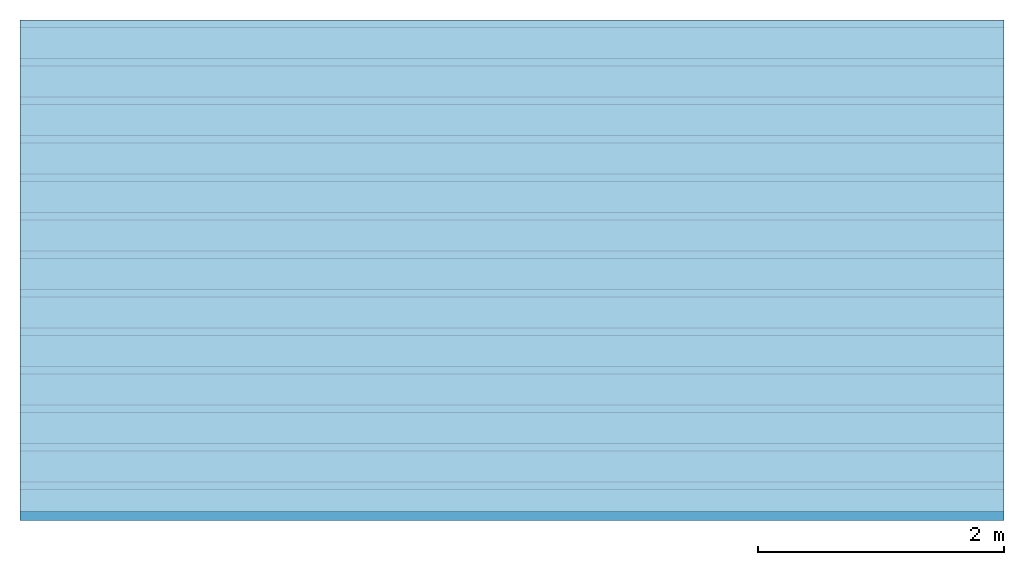
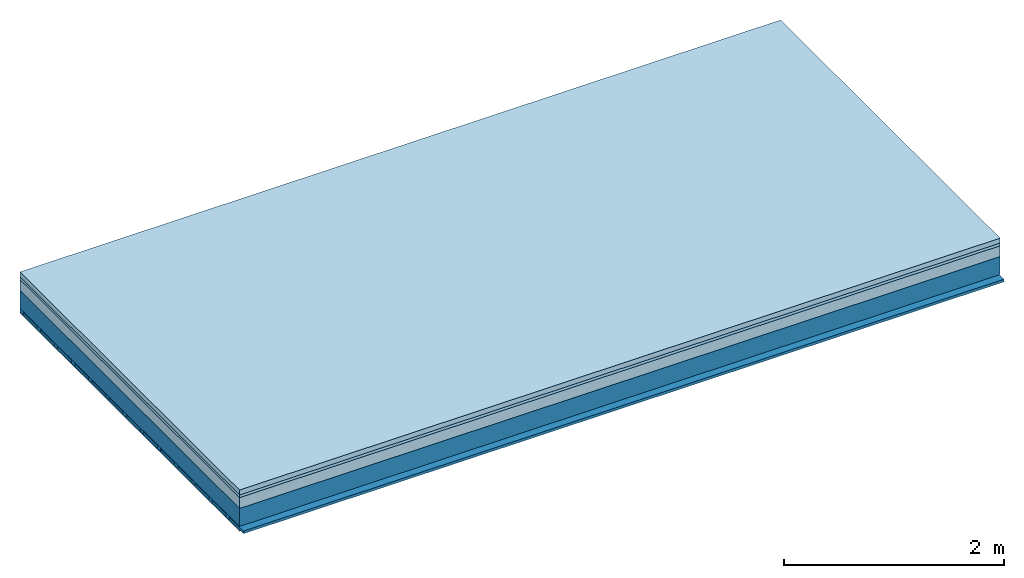
# One storey: 4 plates, 3 members, 1 element without a shape of its own.
"""IFC4 building model written with IfcOpenShell, lengths in metres."""

from ifc_helpers import new_model, si_unit, derived_unit, direction, frame, frame_2d, origin, origin_with_axes, place, context, project, spatial, rectangle, extrude, material, layer, layer_set, type_object, element, aggregate, save


model = new_model("IFC4")

# Units and contexts
plan_context = context("Plan", 3, precision=1e-05, world=origin(), true_north=direction((0.0, 1.0)))
model_context = context("Model", 3, precision=1e-05, world=origin(), true_north=direction((0.0, 1.0)))
ifc_project = project(units=[si_unit("LENGTHUNIT", "METRE"), derived_unit("SOUNDPRESSUREUNIT", [(si_unit("PRESSUREUNIT", "PASCAL", prefix="MICRO"), 0)]), si_unit("ENERGYUNIT", "JOULE", prefix="MEGA"), si_unit("MASSUNIT", "GRAM", prefix="KILO"), derived_unit("THERMALTRANSMITTANCEUNIT", [(si_unit("POWERUNIT", "WATT"), 1), (si_unit("AREAUNIT", "SQUARE_METRE"), -1), (si_unit("THERMODYNAMICTEMPERATUREUNIT", "KELVIN"), -1)]), derived_unit("AREADENSITYUNIT", [(si_unit("MASSUNIT", "GRAM", prefix="KILO"), 1), (si_unit("AREAUNIT", "SQUARE_METRE"), -1)]), derived_unit("USERDEFINED", [(si_unit("ENERGYUNIT", "JOULE", prefix="MEGA"), 1), (si_unit("AREAUNIT", "SQUARE_METRE"), -1)])], contexts=[plan_context, model_context])

# Site, building, storey
site = spatial("IfcSite", under=ifc_project)
building_placement = place(None, origin())
building = spatial("IfcBuilding", under=site, at=building_placement)
storey_placement = place(building_placement, origin())
storey = spatial("IfcBuildingStorey", under=building, at=storey_placement)

# Slab, members, plates
ifc_material_1 = material(Category="04.005")
ifc_layer_1 = layer(ifc_material_1, 0.055, Name="On-material")
ifc_material_2 = material()
ifc_layer_2 = layer(ifc_material_2, 0.03, Name="Impact sound insulation")
ifc_material_3 = material(Category="03.011")
ifc_layer_3 = layer(ifc_material_3, 0.12, Name="on Supporting structure")
ifc_layer_4 = layer(None, 0.2, Name="Supporting structure")
ifc_material_4 = material(Name="of the art")
ifc_layer_5 = layer(ifc_material_4, 0.0, Name="Bond")
ifc_layer_6 = layer(None, 0.04, Name="Battens / profiles")
ifc_material_5 = material(Category="03.007")
ifc_layer_7 = layer(ifc_material_5, 0.015, Name="Ceiling covering 1st layer")
ifc_material_6 = material(Name="Glued joints")
ifc_layer_8 = layer(ifc_material_6, 0.0, Name="Surface / treatment")
ifc_layer_set = layer_set([ifc_layer_1, ifc_layer_2, ifc_layer_3, ifc_layer_4, ifc_layer_5, ifc_layer_6, ifc_layer_7, ifc_layer_8])
slab_type = type_object("IfcSlabType", Name="A1230", PredefinedType="NOTDEFINED", material=ifc_layer_set)
slab_placement = place(None, frame((0.0, 0.0, 0.0), z_axis=(0.0, 0.0, -1.0), x_axis=(1.0, 0.0, 0.0)))
slab = element("IfcSlab", 1, at=slab_placement, inside=storey, type_object=slab_type, material=ifc_layer_set, Name="Slab #1")
ifc_material_7 = material()
member_1_placement = place(slab_placement, origin())
member_1 = element("IfcMember", 2, at=member_1_placement, material=ifc_material_7, Name="Supporting structure", context=plan_context, shape_type="SweptSolid", body=[
    extrude(rectangle(XDim=1.0, YDim=0.2, at=frame_2d((0.5, 0.1), x_axis=(1.0, 0.0))), frame((0.0, 4.0, 0.205), z_axis=(0.0, -1.0, 0.0), x_axis=(1.0, 0.0, 0.0)), (0.0, 0.0, 1.0), 4.0),
    extrude(rectangle(XDim=1.0, YDim=0.2, at=frame_2d((0.5, 0.1), x_axis=(1.0, 0.0))), frame((1.0, 4.0, 0.205), z_axis=(0.0, -1.0, 0.0), x_axis=(1.0, 0.0, 0.0)), (0.0, 0.0, 1.0), 4.0),
    extrude(rectangle(XDim=1.0, YDim=0.2, at=frame_2d((0.5, 0.1), x_axis=(1.0, 0.0))), frame((2.0, 4.0, 0.205), z_axis=(0.0, -1.0, 0.0), x_axis=(1.0, 0.0, 0.0)), (0.0, 0.0, 1.0), 4.0),
    extrude(rectangle(XDim=1.0, YDim=0.2, at=frame_2d((0.5, 0.1), x_axis=(1.0, 0.0))), frame((3.0, 4.0, 0.205), z_axis=(0.0, -1.0, 0.0), x_axis=(1.0, 0.0, 0.0)), (0.0, 0.0, 1.0), 4.0),
    extrude(rectangle(XDim=1.0, YDim=0.2, at=frame_2d((0.5, 0.1), x_axis=(1.0, 0.0))), frame((4.0, 4.0, 0.205), z_axis=(0.0, -1.0, 0.0), x_axis=(1.0, 0.0, 0.0)), (0.0, 0.0, 1.0), 4.0),
    extrude(rectangle(XDim=1.0, YDim=0.2, at=frame_2d((0.5, 0.1), x_axis=(1.0, 0.0))), frame((5.0, 4.0, 0.205), z_axis=(0.0, -1.0, 0.0), x_axis=(1.0, 0.0, 0.0)), (0.0, 0.0, 1.0), 4.0),
    extrude(rectangle(XDim=1.0, YDim=0.2, at=frame_2d((0.5, 0.1), x_axis=(1.0, 0.0))), frame((6.0, 4.0, 0.205), z_axis=(0.0, -1.0, 0.0), x_axis=(1.0, 0.0, 0.0)), (0.0, 0.0, 1.0), 4.0),
    extrude(rectangle(XDim=1.0, YDim=0.2, at=frame_2d((0.5, 0.1), x_axis=(1.0, 0.0))), frame((7.0, 4.0, 0.205), z_axis=(0.0, -1.0, 0.0), x_axis=(1.0, 0.0, 0.0)), (0.0, 0.0, 1.0), 4.0),
])
ifc_material_8 = material()
member_2_placement = place(slab_placement, origin())
member_2 = element("IfcMember", 3, at=member_2_placement, material=ifc_material_8, Name="Battens / profiles", context=plan_context, shape_type="SweptSolid", body=[
    extrude(rectangle(XDim=0.06, YDim=0.04, at=frame_2d((0.03, 0.02), x_axis=(1.0, 0.0))), frame((0.0, 0.0, 0.405), z_axis=(1.0, 0.0, 0.0), x_axis=(0.0, 1.0, 0.0)), (0.0, 0.0, 1.0), 8.0),
    extrude(rectangle(XDim=0.06, YDim=0.04, at=frame_2d((0.03, 0.02), x_axis=(1.0, 0.0))), frame((0.0, 0.313, 0.405), z_axis=(1.0, 0.0, 0.0), x_axis=(0.0, 1.0, 0.0)), (0.0, 0.0, 1.0), 8.0),
    extrude(rectangle(XDim=0.06, YDim=0.04, at=frame_2d((0.03, 0.02), x_axis=(1.0, 0.0))), frame((0.0, 0.626, 0.405), z_axis=(1.0, 0.0, 0.0), x_axis=(0.0, 1.0, 0.0)), (0.0, 0.0, 1.0), 8.0),
    extrude(rectangle(XDim=0.06, YDim=0.04, at=frame_2d((0.03, 0.02), x_axis=(1.0, 0.0))), frame((0.0, 0.939, 0.405), z_axis=(1.0, 0.0, 0.0), x_axis=(0.0, 1.0, 0.0)), (0.0, 0.0, 1.0), 8.0),
    extrude(rectangle(XDim=0.06, YDim=0.04, at=frame_2d((0.03, 0.02), x_axis=(1.0, 0.0))), frame((0.0, 1.252, 0.405), z_axis=(1.0, 0.0, 0.0), x_axis=(0.0, 1.0, 0.0)), (0.0, 0.0, 1.0), 8.0),
    extrude(rectangle(XDim=0.06, YDim=0.04, at=frame_2d((0.03, 0.02), x_axis=(1.0, 0.0))), frame((0.0, 1.565, 0.405), z_axis=(1.0, 0.0, 0.0), x_axis=(0.0, 1.0, 0.0)), (0.0, 0.0, 1.0), 8.0),
    extrude(rectangle(XDim=0.06, YDim=0.04, at=frame_2d((0.03, 0.02), x_axis=(1.0, 0.0))), frame((0.0, 1.878, 0.405), z_axis=(1.0, 0.0, 0.0), x_axis=(0.0, 1.0, 0.0)), (0.0, 0.0, 1.0), 8.0),
    extrude(rectangle(XDim=0.06, YDim=0.04, at=frame_2d((0.03, 0.02), x_axis=(1.0, 0.0))), frame((0.0, 2.191, 0.405), z_axis=(1.0, 0.0, 0.0), x_axis=(0.0, 1.0, 0.0)), (0.0, 0.0, 1.0), 8.0),
    extrude(rectangle(XDim=0.06, YDim=0.04, at=frame_2d((0.03, 0.02), x_axis=(1.0, 0.0))), frame((0.0, 2.504, 0.405), z_axis=(1.0, 0.0, 0.0), x_axis=(0.0, 1.0, 0.0)), (0.0, 0.0, 1.0), 8.0),
    extrude(rectangle(XDim=0.06, YDim=0.04, at=frame_2d((0.03, 0.02), x_axis=(1.0, 0.0))), frame((0.0, 2.817, 0.405), z_axis=(1.0, 0.0, 0.0), x_axis=(0.0, 1.0, 0.0)), (0.0, 0.0, 1.0), 8.0),
    extrude(rectangle(XDim=0.06, YDim=0.04, at=frame_2d((0.03, 0.02), x_axis=(1.0, 0.0))), frame((0.0, 3.13, 0.405), z_axis=(1.0, 0.0, 0.0), x_axis=(0.0, 1.0, 0.0)), (0.0, 0.0, 1.0), 8.0),
    extrude(rectangle(XDim=0.06, YDim=0.04, at=frame_2d((0.03, 0.02), x_axis=(1.0, 0.0))), frame((0.0, 3.443, 0.405), z_axis=(1.0, 0.0, 0.0), x_axis=(0.0, 1.0, 0.0)), (0.0, 0.0, 1.0), 8.0),
    extrude(rectangle(XDim=0.06, YDim=0.04, at=frame_2d((0.03, 0.02), x_axis=(1.0, 0.0))), frame((0.0, 3.756, 0.405), z_axis=(1.0, 0.0, 0.0), x_axis=(0.0, 1.0, 0.0)), (0.0, 0.0, 1.0), 8.0),
])
ifc_material_9 = material()
member_3_placement = place(slab_placement, origin())
member_3 = element("IfcMember", 4, at=member_3_placement, material=ifc_material_9, Name="Cavity", context=plan_context, shape_type="SweptSolid", body=[
    extrude(rectangle(XDim=0.253, YDim=0.03, at=frame_2d((0.1265, 0.015), x_axis=(1.0, 0.0))), frame((0.0, 0.06, 0.415), z_axis=(1.0, 0.0, 0.0), x_axis=(0.0, 1.0, 0.0)), (0.0, 0.0, 1.0), 8.0),
    extrude(rectangle(XDim=0.253, YDim=0.03, at=frame_2d((0.1265, 0.015), x_axis=(1.0, 0.0))), frame((0.0, 0.373, 0.415), z_axis=(1.0, 0.0, 0.0), x_axis=(0.0, 1.0, 0.0)), (0.0, 0.0, 1.0), 8.0),
    extrude(rectangle(XDim=0.253, YDim=0.03, at=frame_2d((0.1265, 0.015), x_axis=(1.0, 0.0))), frame((0.0, 0.686, 0.415), z_axis=(1.0, 0.0, 0.0), x_axis=(0.0, 1.0, 0.0)), (0.0, 0.0, 1.0), 8.0),
    extrude(rectangle(XDim=0.253, YDim=0.03, at=frame_2d((0.1265, 0.015), x_axis=(1.0, 0.0))), frame((0.0, 0.999, 0.415), z_axis=(1.0, 0.0, 0.0), x_axis=(0.0, 1.0, 0.0)), (0.0, 0.0, 1.0), 8.0),
    extrude(rectangle(XDim=0.253, YDim=0.03, at=frame_2d((0.1265, 0.015), x_axis=(1.0, 0.0))), frame((0.0, 1.312, 0.415), z_axis=(1.0, 0.0, 0.0), x_axis=(0.0, 1.0, 0.0)), (0.0, 0.0, 1.0), 8.0),
    extrude(rectangle(XDim=0.253, YDim=0.03, at=frame_2d((0.1265, 0.015), x_axis=(1.0, 0.0))), frame((0.0, 1.625, 0.415), z_axis=(1.0, 0.0, 0.0), x_axis=(0.0, 1.0, 0.0)), (0.0, 0.0, 1.0), 8.0),
    extrude(rectangle(XDim=0.253, YDim=0.03, at=frame_2d((0.1265, 0.015), x_axis=(1.0, 0.0))), frame((0.0, 1.938, 0.415), z_axis=(1.0, 0.0, 0.0), x_axis=(0.0, 1.0, 0.0)), (0.0, 0.0, 1.0), 8.0),
    extrude(rectangle(XDim=0.253, YDim=0.03, at=frame_2d((0.1265, 0.015), x_axis=(1.0, 0.0))), frame((0.0, 2.251, 0.415), z_axis=(1.0, 0.0, 0.0), x_axis=(0.0, 1.0, 0.0)), (0.0, 0.0, 1.0), 8.0),
    extrude(rectangle(XDim=0.253, YDim=0.03, at=frame_2d((0.1265, 0.015), x_axis=(1.0, 0.0))), frame((0.0, 2.564, 0.415), z_axis=(1.0, 0.0, 0.0), x_axis=(0.0, 1.0, 0.0)), (0.0, 0.0, 1.0), 8.0),
    extrude(rectangle(XDim=0.253, YDim=0.03, at=frame_2d((0.1265, 0.015), x_axis=(1.0, 0.0))), frame((0.0, 2.877, 0.415), z_axis=(1.0, 0.0, 0.0), x_axis=(0.0, 1.0, 0.0)), (0.0, 0.0, 1.0), 8.0),
    extrude(rectangle(XDim=0.253, YDim=0.03, at=frame_2d((0.1265, 0.015), x_axis=(1.0, 0.0))), frame((0.0, 3.19, 0.415), z_axis=(1.0, 0.0, 0.0), x_axis=(0.0, 1.0, 0.0)), (0.0, 0.0, 1.0), 8.0),
    extrude(rectangle(XDim=0.253, YDim=0.03, at=frame_2d((0.1265, 0.015), x_axis=(1.0, 0.0))), frame((0.0, 3.503, 0.415), z_axis=(1.0, 0.0, 0.0), x_axis=(0.0, 1.0, 0.0)), (0.0, 0.0, 1.0), 8.0),
    extrude(rectangle(XDim=0.253, YDim=0.03, at=frame_2d((0.1265, 0.015), x_axis=(1.0, 0.0))), frame((0.0, 3.816, 0.415), z_axis=(1.0, 0.0, 0.0), x_axis=(0.0, 1.0, 0.0)), (0.0, 0.0, 1.0), 8.0),
])
plate_1_placement = place(slab_placement, origin())
plate_1 = element("IfcPlate", 5, at=plate_1_placement, material=ifc_material_1, Name="On-material", context=plan_context, shape_type="SweptSolid", body=[
    extrude(rectangle(XDim=8.0, YDim=4.0, at=frame_2d((4.0, 2.0), x_axis=(1.0, 0.0))), origin_with_axes(), (0.0, 0.0, 1.0), 0.055),
])
plate_2_placement = place(slab_placement, origin())
plate_2 = element("IfcPlate", 6, at=plate_2_placement, material=ifc_material_2, Name="Impact sound insulation", context=plan_context, shape_type="SweptSolid", body=[
    extrude(rectangle(XDim=8.0, YDim=4.0, at=frame_2d((4.0, 2.0), x_axis=(1.0, 0.0))), frame((0.0, 0.0, 0.055), z_axis=(0.0, 0.0, 1.0), x_axis=(1.0, 0.0, 0.0)), (0.0, 0.0, 1.0), 0.03),
])
plate_3_placement = place(slab_placement, origin())
plate_3 = element("IfcPlate", 7, at=plate_3_placement, material=ifc_material_3, Name="on Supporting structure", context=plan_context, shape_type="SweptSolid", body=[
    extrude(rectangle(XDim=8.0, YDim=4.0, at=frame_2d((4.0, 2.0), x_axis=(1.0, 0.0))), frame((0.0, 0.0, 0.085), z_axis=(0.0, 0.0, 1.0), x_axis=(1.0, 0.0, 0.0)), (0.0, 0.0, 1.0), 0.12),
])
plate_4_placement = place(slab_placement, origin())
plate_4 = element("IfcPlate", 8, at=plate_4_placement, material=ifc_material_5, Name="Ceiling covering 1st layer", context=plan_context, shape_type="SweptSolid", body=[
    extrude(rectangle(XDim=8.0, YDim=4.0, at=frame_2d((4.0, 2.0), x_axis=(1.0, 0.0))), frame((0.0, 0.0, 0.445), z_axis=(0.0, 0.0, 1.0), x_axis=(1.0, 0.0, 0.0)), (0.0, 0.0, 1.0), 0.015),
])
aggregate(slab, [plate_1, plate_2, plate_3, member_1, member_2, member_3, plate_4])

save(model, "model.ifc")
